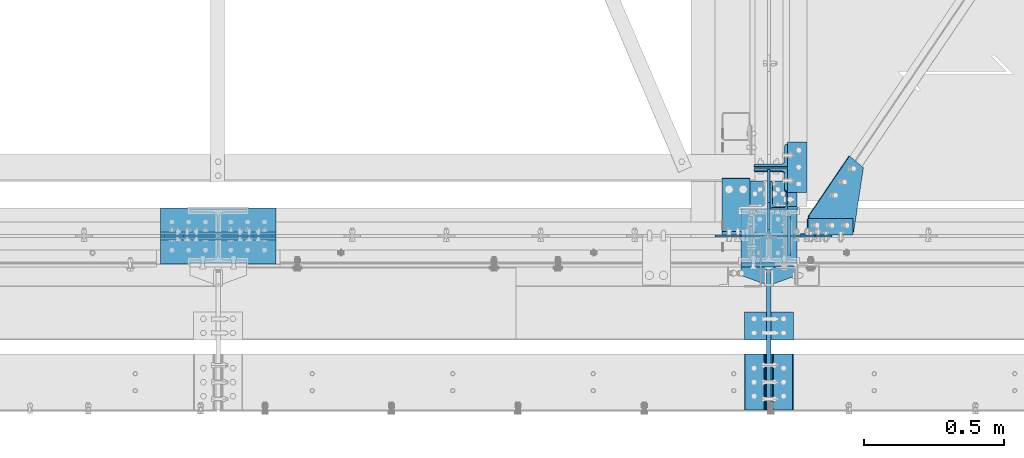
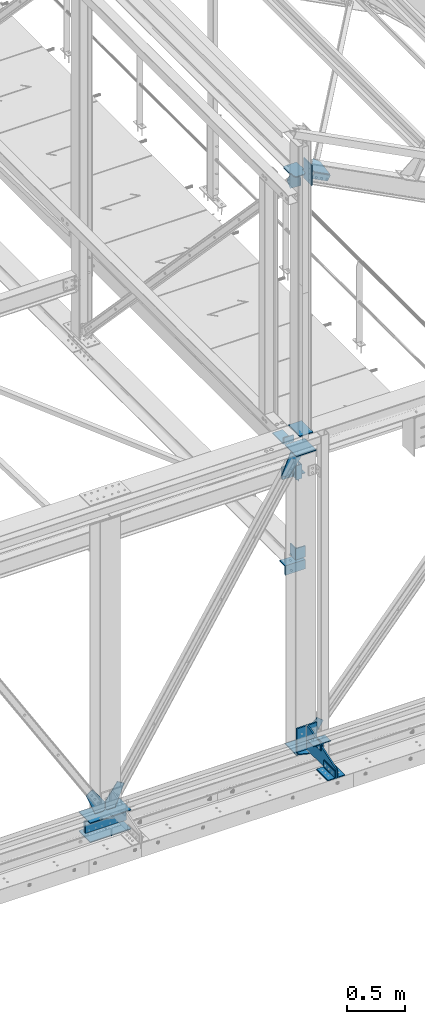
# One storey, part 85 of 496: 27 beams, 3 members, 21 elements without a shape of their own.
"""IFC2X3 building model written with IfcOpenShell, lengths in millimetres."""

from ifc_helpers import new_model, si_unit, frame, frame_2d, origin_with_axes, origin_2d_with_axis, place, context, subcontext, project, spatial, polyline, circle_curve, parameter, trimmed, segment, composite_curve, rectangle, l_section, outline, extrude, clip, halfspace, material, type_object, element, aggregate, save


model = new_model("IFC2X3")

# Units and contexts
model_context = context("Model", 3, precision=1e-05, world=origin_with_axes())
body_context = subcontext(model_context, "Body", "Model", "MODEL_VIEW")
ifc_project = project(units=[si_unit("LENGTHUNIT", "METRE", prefix="MILLI"), si_unit("AREAUNIT", "SQUARE_METRE"), si_unit("VOLUMEUNIT", "CUBIC_METRE"), si_unit("MASSUNIT", "GRAM", prefix="KILO"), si_unit("TIMEUNIT", "SECOND"), si_unit("PLANEANGLEUNIT", "RADIAN"), si_unit("SOLIDANGLEUNIT", "STERADIAN"), si_unit("THERMODYNAMICTEMPERATUREUNIT", "DEGREE_CELSIUS"), si_unit("LUMINOUSINTENSITYUNIT", "LUMEN")], contexts=[model_context])

# Site, building, storey
site_placement = place(None, origin_with_axes())
site = spatial("IfcSite", under=ifc_project, at=site_placement, CompositionType="ELEMENT")
building_placement = place(site_placement, origin_with_axes())
building = spatial("IfcBuilding", under=site, at=building_placement, Name="Undefined", CompositionType="ELEMENT")
storey_placement = place(building_placement, origin_with_axes())
storey = spatial("IfcBuildingStorey", under=building, at=storey_placement, Name="Undefined", CompositionType="ELEMENT", Elevation=0.0)

# Assembly, beam
assembly_1_placement = place(storey_placement, origin_with_axes())
assembly_1 = element("IfcElementAssembly", 1, at=assembly_1_placement, inside=storey, AssemblyPlace="NOTDEFINED", PredefinedType="NOTDEFINED")
ifc_material = material(Name="Undefined/S235-E24")
beam_type_1 = type_object("IfcBeamType", PredefinedType="NOTDEFINED")
beam_1_placement = place(assembly_1_placement, frame((23506.5000567969, 125.0, 8100.0), z_axis=(-1.0, 0.0, 0.0), x_axis=(0.0, 0.0, -1.0)))
beam_1 = element("IfcBeam", 2, at=beam_1_placement, type_object=beam_type_1, material=ifc_material, context=body_context, shape_type="SweptSolid", body=[
    extrude(l_section(Depth=60.0, Width=60.0, Thickness=6.0, FilletRadius=8.0, EdgeRadius=4.0, at=origin_2d_with_axis()), frame((149.999995982835, 4.54747350886464e-12, 3.63797880709171e-12), z_axis=(-1.0, 0.0, 0.0), x_axis=(0.0, -1.0, 0.0)), (0.0, 0.0, 1.0), 150.0),
])
aggregate(assembly_1, [beam_1])

assembly_2_placement = place(storey_placement, origin_with_axes())
assembly_2 = element("IfcElementAssembly", 3, at=assembly_2_placement, inside=storey, AssemblyPlace="NOTDEFINED", PredefinedType="NOTDEFINED")
beam_type_2 = type_object("IfcBeamType", PredefinedType="NOTDEFINED")
beam_2_placement = place(assembly_2_placement, frame((21304.9998196885, 0.0, 4994.99960117714), z_axis=(0.0, 1.0, 0.0), x_axis=(0.999999999995014, 0.0, -3.15800000114453e-06)))
beam_2 = element("IfcBeam", 4, at=beam_2_placement, type_object=beam_type_2, material=ifc_material, context=body_context, shape_type="SweptSolid", body=[
    extrude(rectangle(XDim=10.0, YDim=200.0, at=origin_2d_with_axis()), frame((410.0, 0.0, 0.0), z_axis=(-1.0, 0.0, 0.0), x_axis=(0.0, -1.0, 0.0)), (0.0, 0.0, 1.0), 410.0),
])
aggregate(assembly_2, [beam_2])

# Assembly, beams
assembly_3_placement = place(storey_placement, origin_with_axes())
assembly_3 = element("IfcElementAssembly", 5, at=assembly_3_placement, inside=storey, Name="MONTANT", AssemblyPlace="NOTDEFINED", PredefinedType="NOTDEFINED")
beam_3_placement = place(assembly_3_placement, frame((23369.9982817512, 0.0, 8354.99930736483), z_axis=(0.0, 1.0, 0.0), x_axis=(1.0, 0.0, 0.0)))
beam_3 = element("IfcBeam", 6, at=beam_3_placement, type_object=beam_type_2, material=ifc_material, context=body_context, shape_type="SweptSolid", body=[
    extrude(rectangle(XDim=10.0, YDim=200.0, at=origin_2d_with_axis()), frame((200.003108907451, 1.3235095531086e-21, 0.0), z_axis=(-1.0, 0.0, 0.0), x_axis=(0.0, -1.0, 0.0)), (0.0, 0.0, 1.0), 200.0),
])
beam_4_placement = place(assembly_3_placement, frame((23369.9982812412, 0.0, 5195.00069263517), z_axis=(0.0, 1.0, 0.0), x_axis=(1.0, 0.0, 0.0)))
beam_4 = element("IfcBeam", 7, at=beam_4_placement, type_object=beam_type_2, material=ifc_material, context=body_context, shape_type="SweptSolid", body=[
    extrude(rectangle(XDim=10.0, YDim=200.0, at=origin_2d_with_axis()), frame((200.003108907451, 1.3235095531086e-21, 0.0), z_axis=(-1.0, 0.0, 0.0), x_axis=(0.0, -1.0, 0.0)), (0.0, 0.0, 1.0), 200.0),
])

# Assembly, beam
assembly_4_placement = place(storey_placement, origin_with_axes())
assembly_4 = element("IfcElementAssembly", 8, at=assembly_4_placement, inside=storey, Name="MONTANT", AssemblyPlace="NOTDEFINED", PredefinedType="NOTDEFINED")
beam_5_placement = place(assembly_4_placement, frame((21304.9998196885, 0.0, 5195.00039882286), z_axis=(0.0, 1.0, 0.0), x_axis=(0.999999999995014, 0.0, 3.15800000114453e-06)))
beam_5 = element("IfcBeam", 9, at=beam_5_placement, type_object=beam_type_2, material=ifc_material, context=body_context, shape_type="SweptSolid", body=[
    extrude(rectangle(XDim=10.0, YDim=200.0, at=origin_2d_with_axis()), frame((410.0, 0.0, 0.0), z_axis=(-1.0, 0.0, 0.0), x_axis=(0.0, -1.0, 0.0)), (0.0, 0.0, 1.0), 410.0),
])

assembly_5_placement = place(storey_placement, origin_with_axes())
assembly_5 = element("IfcElementAssembly", 10, at=assembly_5_placement, inside=storey, AssemblyPlace="NOTDEFINED", PredefinedType="NOTDEFINED")
beam_type_3 = type_object("IfcBeamType", PredefinedType="NOTDEFINED")
beam_6_placement = place(assembly_5_placement, frame((23517.4921676285, -270.0, 5409.99824538435), z_axis=(0.0, 0.0, -1.0), x_axis=(0.0, -1.0, 0.0)))
beam_6 = element("IfcBeam", 11, at=beam_6_placement, type_object=beam_type_3, material=ifc_material, context=body_context, shape_type="SweptSolid", body=[
    extrude(l_section(Depth=80.0, Width=80.0, Thickness=8.0, FilletRadius=10.0, EdgeRadius=5.0, at=origin_2d_with_axis()), frame((100.000000000021, 5.72981662116945e-11, -4.09272615797818e-12), z_axis=(-1.0, 0.0, 0.0), x_axis=(0.0, -1.0, 0.0)), (0.0, 0.0, 1.0), 100.0),
])
aggregate(assembly_5, [beam_6])

assembly_6_placement = place(storey_placement, origin_with_axes())
assembly_6 = element("IfcElementAssembly", 12, at=assembly_6_placement, inside=storey, AssemblyPlace="NOTDEFINED", PredefinedType="NOTDEFINED")
beam_7_placement = place(assembly_6_placement, frame((23422.5, -370.0, 5409.99824538435), z_axis=(0.0, 0.0, -1.0), x_axis=(0.0, 1.0, 0.0)))
beam_7 = element("IfcBeam", 13, at=beam_7_placement, type_object=beam_type_3, material=ifc_material, context=body_context, shape_type="SweptSolid", body=[
    extrude(l_section(Depth=80.0, Width=80.0, Thickness=8.0, FilletRadius=10.0, EdgeRadius=5.0, at=origin_2d_with_axis()), frame((100.000000000021, 5.72981662116945e-11, -4.09272615797818e-12), z_axis=(-1.0, 0.0, 0.0), x_axis=(0.0, -1.0, 0.0)), (0.0, 0.0, 1.0), 100.0),
])
aggregate(assembly_6, [beam_7])

assembly_7_placement = place(storey_placement, origin_with_axes())
assembly_7 = element("IfcElementAssembly", 14, at=assembly_7_placement, inside=storey, AssemblyPlace="NOTDEFINED", PredefinedType="NOTDEFINED")
beam_8_placement = place(assembly_7_placement, frame((23517.4921676285, -620.0, 5269.99824538435), z_axis=(0.0, 0.0, 1.0), x_axis=(0.0, 1.0, 0.0)))
beam_8 = element("IfcBeam", 15, at=beam_8_placement, type_object=beam_type_3, material=ifc_material, context=body_context, shape_type="SweptSolid", body=[
    extrude(l_section(Depth=80.0, Width=80.0, Thickness=8.0, FilletRadius=10.0, EdgeRadius=5.0, at=origin_2d_with_axis()), frame((200.0, 0.0, 0.0), z_axis=(-1.0, 0.0, 0.0), x_axis=(0.0, -1.0, 0.0)), (0.0, 0.0, 1.0), 200.0),
])
aggregate(assembly_7, [beam_8])

assembly_8_placement = place(storey_placement, origin_with_axes())
assembly_8 = element("IfcElementAssembly", 16, at=assembly_8_placement, inside=storey, AssemblyPlace="NOTDEFINED", PredefinedType="NOTDEFINED")
beam_9_placement = place(assembly_8_placement, frame((23422.5, -420.0, 5269.99824538435), z_axis=(0.0, 0.0, 1.0), x_axis=(0.0, -1.0, 0.0)))
beam_9 = element("IfcBeam", 17, at=beam_9_placement, type_object=beam_type_3, material=ifc_material, context=body_context, shape_type="SweptSolid", body=[
    extrude(l_section(Depth=80.0, Width=80.0, Thickness=8.0, FilletRadius=10.0, EdgeRadius=5.0, at=origin_2d_with_axis()), frame((200.0, 0.0, 0.0), z_axis=(-1.0, 0.0, 0.0), x_axis=(0.0, -1.0, 0.0)), (0.0, 0.0, 1.0), 200.0),
])
aggregate(assembly_8, [beam_9])

# Assembly, beams
assembly_9_placement = place(storey_placement, origin_with_axes())
assembly_9 = element("IfcElementAssembly", 18, at=assembly_9_placement, inside=storey, Name="CONSOLE", AssemblyPlace="NOTDEFINED", PredefinedType="NOTDEFINED")
beam_type_4 = type_object("IfcBeamType", PredefinedType="NOTDEFINED")
beam_10_placement = place(assembly_9_placement, frame((23370.0, -110.0, 5224.99824534403), z_axis=(0.0, 0.0, 1.0), x_axis=(0.0, -1.0, 0.0)))
beam_10 = element("IfcBeam", 19, at=beam_10_placement, type_object=beam_type_4, material=ifc_material, context=body_context, shape_type="SweptSolid", body=[
    extrude(outline(polyline([(0.0, 0.0), (30.0, 0.0), (60.0, 82.5), (60.0, 117.5), (30.0, 200.0), (0.0, 200.0), (0.0, 0.0)])), frame((0.0, 0.0, -5.0), z_axis=(0.0, 0.0, 1.0), x_axis=(1.0, 0.0, 0.0)), (0.0, 0.0, 1.0), 10.0),
])
beam_type_5 = type_object("IfcBeamType", PredefinedType="NOTDEFINED")
beam_11_placement = place(assembly_9_placement, frame((23470.0, -102.5, 5479.99824538435), z_axis=(1.0, 0.0, 0.0), x_axis=(0.0, 0.0, -1.0)))
beam_11 = element("IfcBeam", 20, at=beam_11_placement, type_object=beam_type_5, material=ifc_material, context=body_context, shape_type="SweptSolid", body=[
    extrude(rectangle(XDim=15.0, YDim=200.0, at=origin_2d_with_axis()), frame((265.000000057562, 0.0, 0.0), z_axis=(-1.0, 0.0, 0.0), x_axis=(0.0, -1.0, 0.0)), (0.0, 0.0, 1.0), 265.0),
])
beam_type_6 = type_object("IfcBeamType", PredefinedType="NOTDEFINED")
beam_12_placement = place(assembly_9_placement, frame((23470.0, -620.0, 5229.99824538435), z_axis=(-1.0, 0.0, 0.0), x_axis=(0.0, 0.0, 1.0)))
beam_12 = element("IfcBeam", 21, at=beam_12_placement, type_object=beam_type_6, material=ifc_material, Name="CONSOLE", context=body_context, shape_type="SweptSolid", body=[
    extrude(outline(polyline([(0.0, 0.0), (100.0, 0.0), (250.0, 450.0), (250.0, 510.0), (19.9999999424381, 510.0), (-5.53045894918671e-08, 490.0), (0.0, 0.0)])), frame((0.0, 0.0, -7.5), z_axis=(0.0, 0.0, 1.0), x_axis=(1.0, 0.0, 0.0)), (0.0, 0.0, 1.0), 15.0),
])
aggregate(assembly_9, [beam_10, beam_11, beam_12])

# Assembly, beam
assembly_10_placement = place(storey_placement, origin_with_axes())
assembly_10 = element("IfcElementAssembly", 22, at=assembly_10_placement, inside=storey, AssemblyPlace="NOTDEFINED", PredefinedType="NOTDEFINED")
beam_type_7 = type_object("IfcBeamType", PredefinedType="NOTDEFINED")
beam_13_placement = place(assembly_10_placement, frame((23571.5000574129, 335.0, 7915.0), z_axis=(0.0, 0.0, -1.0), x_axis=(0.0, -1.0, 0.0)))
beam_13 = element("IfcBeam", 23, at=beam_13_placement, type_object=beam_type_7, material=ifc_material, context=body_context, shape_type="SweptSolid", body=[
    extrude(l_section(Depth=70.0, Width=70.0, Thickness=7.0, FilletRadius=9.0, EdgeRadius=4.5, at=origin_2d_with_axis()), frame((180.0, 0.0, 0.0), z_axis=(-1.0, 0.0, 0.0), x_axis=(0.0, -1.0, 0.0)), (0.0, 0.0, 1.0), 180.0),
])
aggregate(assembly_10, [beam_13])

# Assembly, member
assembly_11_placement = place(storey_placement, origin_with_axes())
assembly_11 = element("IfcElementAssembly", 24, at=assembly_11_placement, inside=storey, AssemblyPlace="NOTDEFINED", PredefinedType="NOTDEFINED")
member_type_1 = type_object("IfcMemberType", PredefinedType="NOTDEFINED")
member_1_placement = place(assembly_11_placement, frame((23755.3143945004, 33.0000627956342, 11104.2490486859), z_axis=(0.0, 1.0, 0.0), x_axis=(-0.887870604061621, -1.29999898490562e-08, 0.460093241031915)))
member_1 = element("IfcMember", 25, at=member_1_placement, type_object=member_type_1, material=ifc_material, context=body_context, shape_type="SweptSolid", body=[
    extrude(l_section(Depth=60.0, Width=60.0, Thickness=6.0, FilletRadius=8.0, EdgeRadius=4.0, at=origin_2d_with_axis()), frame((180.0, 0.0, 0.0), z_axis=(-1.0, 0.0, 0.0), x_axis=(0.0, -1.0, 0.0)), (0.0, 0.0, 1.0), 180.0),
])
aggregate(assembly_11, [member_1])

# Assembly, beam
assembly_12_placement = place(storey_placement, origin_with_axes())
assembly_12 = element("IfcElementAssembly", 26, at=assembly_12_placement, inside=storey, AssemblyPlace="NOTDEFINED", PredefinedType="NOTDEFINED")
beam_type_8 = type_object("IfcBeamType", PredefinedType="NOTDEFINED")
beam_14_placement = place(assembly_12_placement, frame((23805.2587665873, 242.886272340963, 11115.5356180809), z_axis=(0.460093364927087, 0.0, 0.887870539859315), x_axis=(-0.706117074921334, 0.606225534605613, 0.365908837959236)))
beam_14 = element("IfcBeam", 27, at=beam_14_placement, type_object=beam_type_8, material=ifc_material, context=body_context, shape_type="SweptSolid", body=[
    extrude(outline(polyline([(0.0, 0.0), (70.0, 0.0), (70.0000000011751, 269.669891357869), (34.9265289317609, 315.681945801189), (-108.226165771541, 206.561325072886), (0.0, 0.0)])), frame((0.0, 0.0, -3.0), z_axis=(0.0, 0.0, 1.0), x_axis=(1.0, 0.0, 0.0)), (0.0, 0.0, 1.0), 6.0),
])
aggregate(assembly_12, [beam_14])

assembly_13_placement = place(storey_placement, origin_with_axes())
assembly_13 = element("IfcElementAssembly", 28, at=assembly_13_placement, inside=storey, Name="MONTANT", AssemblyPlace="NOTDEFINED", PredefinedType="NOTDEFINED")
beam_type_9 = type_object("IfcBeamType", PredefinedType="NOTDEFINED")
beam_15_placement = place(assembly_13_placement, frame((23470.0, 100.0, 8555.0), z_axis=(1.0, 0.0, 0.0), x_axis=(0.0, -1.0, 0.0)))
beam_15 = element("IfcBeam", 29, at=beam_15_placement, type_object=beam_type_9, material=ifc_material, context=body_context, shape_type="SweptSolid", body=[
    extrude(rectangle(XDim=10.0, YDim=133.0, at=origin_2d_with_axis()), frame((200.0, 0.0, 0.0), z_axis=(-1.0, 0.0, 0.0), x_axis=(0.0, -1.0, 0.0)), (0.0, 0.0, 1.0), 200.0),
])

assembly_14_placement = place(storey_placement, origin_with_axes())
assembly_14 = element("IfcElementAssembly", 30, at=assembly_14_placement, inside=storey, AssemblyPlace="NOTDEFINED", PredefinedType="NOTDEFINED")
beam_type_10 = type_object("IfcBeamType", PredefinedType="NOTDEFINED")
beam_16_placement = place(assembly_14_placement, frame((23303.4999986482, 106.0, 8490.0), z_axis=(0.0, 1.0, 0.0), x_axis=(1.0, 0.0, 0.0)))
beam_16 = element("IfcBeam", 31, at=beam_16_placement, type_object=beam_type_10, material=ifc_material, context=body_context, shape_type="Clipping", body=[
    clip(extrude(l_section(Depth=200.0, Width=100.0, Thickness=10.0, FilletRadius=15.0, EdgeRadius=7.5, at=origin_2d_with_axis()), frame((100.000000000021, 5.72981662116945e-11, -4.09272615797818e-12), z_axis=(-1.0, 0.0, 0.0), x_axis=(0.0, -1.0, 0.0)), (0.0, 0.0, 1.0), 100.0), halfspace(frame((100.0, -20.0, -100.0), z_axis=(0.0, -1.0, 0.0), x_axis=(-1.0, 0.0, 0.0)), False)),
])
aggregate(assembly_14, [beam_16])

assembly_15_placement = place(storey_placement, origin_with_axes())
assembly_15 = element("IfcElementAssembly", 32, at=assembly_15_placement, inside=storey, Name="TRAVERSE SHED", AssemblyPlace="NOTDEFINED", PredefinedType="NOTDEFINED")
beam_type_11 = type_object("IfcBeamType", PredefinedType="NOTDEFINED")
beam_17_placement = place(assembly_15_placement, frame((23541.5, 0.0, 11360.8449760213), z_axis=(0.0, -1.0, 0.0), x_axis=(0.0, 0.0, -1.0)))
beam_17 = element("IfcBeam", 33, at=beam_17_placement, type_object=beam_type_11, material=ifc_material, context=body_context, shape_type="SweptSolid", body=[
    extrude(rectangle(XDim=10.0, YDim=140.0, at=origin_2d_with_axis()), frame((215.684581879355, 0.0, 0.0), z_axis=(-1.0, 0.0, 0.0), x_axis=(0.0, -1.0, 0.0)), (0.0, 0.0, 1.0), 215.68),
])
aggregate(assembly_15, [beam_17])

# Assembly, member
assembly_16_placement = place(storey_placement, origin_with_axes())
assembly_16 = element("IfcElementAssembly", 34, at=assembly_16_placement, inside=storey, AssemblyPlace="NOTDEFINED", PredefinedType="NOTDEFINED")
member_type_2 = type_object("IfcMemberType", PredefinedType="NOTDEFINED")
member_2_placement = place(assembly_16_placement, frame((23476.5000567968, 287.037388451991, 8010.96467073948), z_axis=(-1.0, 0.0, 0.0), x_axis=(0.0, -0.031410887010906, -0.999506556345274)))
member_2 = element("IfcMember", 35, at=member_2_placement, type_object=member_type_2, material=ifc_material, context=body_context, shape_type="SweptSolid", body=[
    extrude(l_section(Depth=120.0, Width=80.0, Thickness=10.0, FilletRadius=11.0, EdgeRadius=5.5, at=origin_2d_with_axis()), frame((120.0, 0.0, 0.0), z_axis=(-1.0, 0.0, 0.0), x_axis=(0.0, -1.0, 0.0)), (0.0, 0.0, 1.0), 120.0),
])
aggregate(assembly_16, [member_2])

assembly_17_placement = place(storey_placement, origin_with_axes())
assembly_17 = element("IfcElementAssembly", 36, at=assembly_17_placement, inside=storey, AssemblyPlace="NOTDEFINED", PredefinedType="NOTDEFINED")
member_3_placement = place(assembly_17_placement, frame((23476.5000567969, 197.309617474838, 7893.72527706323), z_axis=(-1.0, 0.0, 0.0), x_axis=(0.0, 0.031410887010906, 0.999506556345274)))
member_3 = element("IfcMember", 37, at=member_3_placement, type_object=member_type_2, material=ifc_material, context=body_context, shape_type="SweptSolid", body=[
    extrude(l_section(Depth=120.0, Width=80.0, Thickness=10.0, FilletRadius=11.0, EdgeRadius=5.5, at=origin_2d_with_axis()), frame((120.0, 0.0, 0.0), z_axis=(-1.0, 0.0, 0.0), x_axis=(0.0, -1.0, 0.0)), (0.0, 0.0, 1.0), 120.0),
])
aggregate(assembly_17, [member_3])

# Assembly, beam
assembly_18_placement = place(storey_placement, origin_with_axes())
assembly_18 = element("IfcElementAssembly", 38, at=assembly_18_placement, inside=storey, AssemblyPlace="NOTDEFINED", PredefinedType="NOTDEFINED")
beam_type_12 = type_object("IfcBeamType", PredefinedType="NOTDEFINED")
beam_18_placement = place(assembly_18_placement, frame((23523.5000000436, 145.002301978551, 7224.49999757089), z_axis=(0.0, 1.0, 0.0), x_axis=(0.0, 0.0, -1.0)))
beam_18 = element("IfcBeam", 39, at=beam_18_placement, type_object=beam_type_12, material=ifc_material, context=body_context, shape_type="SweptSolid", body=[
    extrude(l_section(Depth=100.0, Width=100.0, Thickness=10.0, FilletRadius=12.0, EdgeRadius=6.0, at=origin_2d_with_axis()), frame((120.0, 0.0, 0.0), z_axis=(-1.0, 0.0, 0.0), x_axis=(0.0, -1.0, 0.0)), (0.0, 0.0, 1.0), 120.0),
])
aggregate(assembly_18, [beam_18])

assembly_19_placement = place(storey_placement, origin_with_axes())
assembly_19 = element("IfcElementAssembly", 40, at=assembly_19_placement, inside=storey, AssemblyPlace="NOTDEFINED", PredefinedType="NOTDEFINED")
beam_19_placement = place(assembly_19_placement, frame((23369.9992355, 145.003057953993, 7029.0), z_axis=(0.0, 0.0, -1.0), x_axis=(0.999999999883108, 1.52899999980981e-05, 0.0)))
beam_19 = element("IfcBeam", 41, at=beam_19_placement, type_object=beam_type_12, material=ifc_material, context=body_context, shape_type="SweptSolid", body=[
    extrude(l_section(Depth=100.0, Width=100.0, Thickness=10.0, FilletRadius=12.0, EdgeRadius=6.0, at=origin_2d_with_axis()), frame((200.0, 0.0, 0.0), z_axis=(-1.0, 0.0, 0.0), x_axis=(0.0, -1.0, 0.0)), (0.0, 0.0, 1.0), 200.0),
])
aggregate(assembly_19, [beam_19])

# Beam
beam_type_13 = type_object("IfcBeamType", PredefinedType="NOTDEFINED")
beam_20_placement = place(assembly_13_placement, frame((23403.5, 195.0, 11231.0), z_axis=(0.0, 0.0, 1.0), x_axis=(0.0, -1.0, 0.0)))
beam_20 = element("IfcBeam", 42, at=beam_20_placement, type_object=beam_type_13, material=ifc_material, Name="PLAT", context=body_context, shape_type="SweptSolid", body=[
    extrude(outline(composite_curve([segment(trimmed(circle_curve(frame_2d((10.0, 10.0), x_axis=(-1.0, 0.0)), 10.0), [parameter(0.0)], [parameter(1.5707963267949)], True, "PARAMETER"), True, "CONTINUOUS"), segment(polyline([(9.99999999997453, 6.91215973347425e-11), (124.5, 0.0), (124.5, 9.0), (172.25, 9.0), (192.25, 29.0), (192.25, 104.0), (172.25, 124.0), (124.0, 124.0), (124.0, 140.0), (10.0, 140.0)]), True, "CONTINUOUS"), segment(trimmed(circle_curve(frame_2d((10.0, 130.0), x_axis=(0.0, 1.0)), 10.0), [parameter(0.0)], [parameter(1.5707963267949)], True, "PARAMETER"), True, "CONTINUOUS"), segment(polyline([(0.0, 130.0), (-1.81898940354586e-10, 10.0000000000073)]), True, "CONTINUOUS")], self_intersect=True)), frame((0.0, 0.0, -5.0), z_axis=(0.0, 0.0, 1.0), x_axis=(1.0, 0.0, 0.0)), (0.0, 0.0, 1.0), 10.0),
])

beam_type_14 = type_object("IfcBeamType", PredefinedType="NOTDEFINED")
beam_21_placement = place(assembly_13_placement, frame((23470.0, 2.75000000000006, 11226.0), z_axis=(-1.0, 0.0, 0.0), x_axis=(0.0, 1.0, 0.0)))
beam_21 = element("IfcBeam", 43, at=beam_21_placement, type_object=beam_type_14, material=ifc_material, context=body_context, shape_type="SweptSolid", body=[
    extrude(outline(polyline([(0.0, 20.0), (20.0, 0.0), (117.25, 0.0), (233.212432861328, 179.537170410156), (175.309005737305, 234.738555908203), (0.0, 100.0), (0.0, 20.0)])), frame((0.0, 0.0, -4.0), z_axis=(0.0, 0.0, 1.0), x_axis=(1.0, 0.0, 0.0)), (0.0, 0.0, 1.0), 8.0),
])

aggregate(assembly_13, [beam_15, beam_21, beam_20])

# Assembly, beam
assembly_20_placement = place(storey_placement, origin_with_axes())
assembly_20 = element("IfcElementAssembly", 44, at=assembly_20_placement, inside=storey, AssemblyPlace="NOTDEFINED", PredefinedType="NOTDEFINED")
beam_type_15 = type_object("IfcBeamType", PredefinedType="NOTDEFINED")
beam_22_placement = place(assembly_20_placement, frame((21304.9998354776, 8.5, 5095.0), z_axis=(0.0, 0.0, 1.0), x_axis=(1.0, 0.0, 0.0)))
beam_22 = element("IfcBeam", 45, at=beam_22_placement, type_object=beam_type_15, material=ifc_material, context=body_context, shape_type="SweptSolid", body=[
    extrude(rectangle(XDim=10.0, YDim=120.0, at=origin_2d_with_axis()), frame((410.0, 0.0, 0.0), z_axis=(-1.0, 0.0, 0.0), x_axis=(0.0, -1.0, 0.0)), (0.0, 0.0, 1.0), 410.0),
])
aggregate(assembly_20, [beam_22])

assembly_21_placement = place(storey_placement, origin_with_axes())
assembly_21 = element("IfcElementAssembly", 46, at=assembly_21_placement, inside=storey, AssemblyPlace="NOTDEFINED", PredefinedType="NOTDEFINED")
beam_23_placement = place(assembly_21_placement, frame((21304.9998354776, -8.5, 5095.0), z_axis=(0.0, 0.0, 1.0), x_axis=(1.0, 0.0, 0.0)))
beam_23 = element("IfcBeam", 47, at=beam_23_placement, type_object=beam_type_15, material=ifc_material, context=body_context, shape_type="SweptSolid", body=[
    extrude(rectangle(XDim=10.0, YDim=120.0, at=origin_2d_with_axis()), frame((410.0, 0.0, 0.0), z_axis=(-1.0, 0.0, 0.0), x_axis=(0.0, -1.0, 0.0)), (0.0, 0.0, 1.0), 410.0),
])
aggregate(assembly_21, [beam_23])

# Beam
beam_type_16 = type_object("IfcBeamType", PredefinedType="NOTDEFINED")
beam_24_placement = place(assembly_3_placement, frame((23473.25, 0.0, 5300.0), z_axis=(0.0, -1.0, 0.0), x_axis=(0.0, 0.0, -1.0)))
beam_24 = element("IfcBeam", 48, at=beam_24_placement, type_object=beam_type_16, material=ifc_material, context=body_context, shape_type="SweptSolid", body=[
    extrude(outline(polyline([(0.0, 0.0), (80.00000000008, 8.00355337560177e-11), (99.9998580598133, 19.9999999994963), (99.9993133544922, 96.7513885498047), (-92.2446060180664, 221.910827636719), (-144.173431396484, 161.055267333984), (0.0, 0.0)])), frame((0.0, 0.0, -4.0), z_axis=(0.0, 0.0, 1.0), x_axis=(1.0, 0.0, 0.0)), (0.0, 0.0, 1.0), 8.0),
])

beam_type_17 = type_object("IfcBeamType", PredefinedType="NOTDEFINED")
beam_25_placement = place(assembly_3_placement, frame((23369.9982815342, 0.0, 8349.99930736483), z_axis=(0.0, 1.0, 0.0), x_axis=(0.999999999974374, 0.0, 7.15900000422673e-06)))
beam_25 = element("IfcBeam", 49, at=beam_25_placement, type_object=beam_type_17, material=ifc_material, context=body_context, shape_type="SweptSolid", body=[
    extrude(outline(polyline([(0.0, 0.0), (76.7517166138678, 0.0), (96.7515747071295, 19.9999999994966), (96.7510070801764, 100.000000000093), (-23.7460117340306, 266.200805664314), (-91.7897796631623, 224.128860473843), (0.0, 0.0)])), frame((0.0, 0.0, -4.0), z_axis=(0.0, 0.0, 1.0), x_axis=(1.0, 0.0, 0.0)), (0.0, 0.0, 1.0), 8.0),
])

aggregate(assembly_3, [beam_24, beam_25, beam_3, beam_4])

beam_26_placement = place(assembly_4_placement, frame((21513.2498361998, 0.0, 5200.00068813109), z_axis=(0.0, 1.0, 0.0), x_axis=(0.0, 0.0, 1.0)))
beam_26 = element("IfcBeam", 50, at=beam_26_placement, type_object=beam_type_17, material=ifc_material, context=body_context, shape_type="SweptSolid", body=[
    extrude(outline(polyline([(0.0, 20.0), (20.0, 0.0), (100.0, 0.0), (266.200958252063, 120.495819092277), (224.129531860523, 188.539886475028), (8.6708132585045e-07, 96.7515563964844), (0.0, 20.0)])), frame((0.0, 0.0, -4.0), z_axis=(0.0, 0.0, 1.0), x_axis=(1.0, 0.0, 0.0)), (0.0, 0.0, 1.0), 8.0),
])

beam_27_placement = place(assembly_4_placement, frame((21506.7498362072, 0.0, 5200.00068846909), z_axis=(0.0, 1.0, 0.0), x_axis=(-1.0, 0.0, 0.0)))
beam_27 = element("IfcBeam", 51, at=beam_27_placement, type_object=beam_type_17, material=ifc_material, context=body_context, shape_type="SweptSolid", body=[
    extrude(outline(polyline([(0.0, 20.0), (20.0, 0.0), (96.7515563964844, -4.38376446254551e-10), (188.539886473794, 224.129531859497), (120.495826720227, 266.200958251407), (0.0, 100.0), (0.0, 20.0)])), frame((0.0, 0.0, -4.0), z_axis=(0.0, 0.0, 1.0), x_axis=(1.0, 0.0, 0.0)), (0.0, 0.0, 1.0), 8.0),
])

aggregate(assembly_4, [beam_26, beam_27, beam_5])

save(model, "model.ifc")
